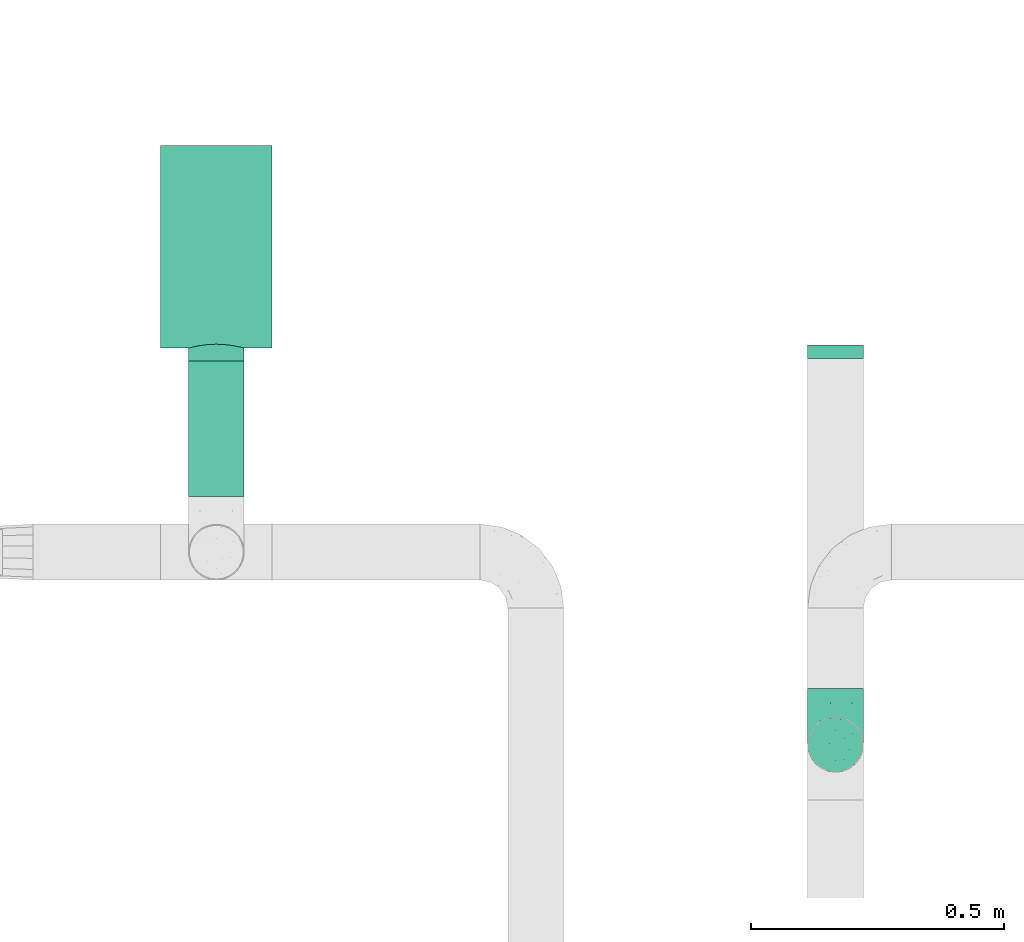
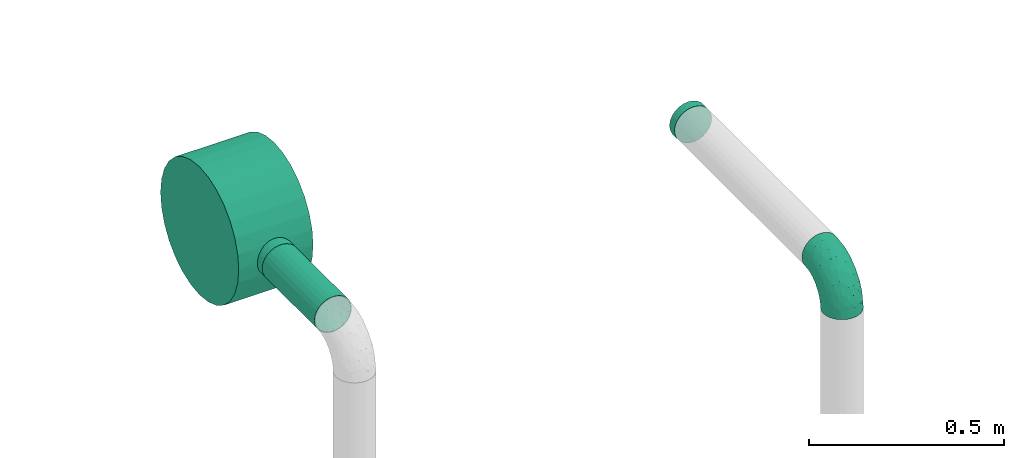
# One storey, part 82 of 103: 3 flow fittings, 1 flow segment.
"""IFC2X3 building model written with IfcOpenShell, lengths in millimetres."""

from ifc_helpers import new_model, entity, si_unit, converted_unit, derived_unit, direction, frame, origin_with_axes, origin_2d_with_axis, place, context, subcontext, project, spatial, hollow_circle, extrude, open_shell, surface_model, source, transform, mapped, material, layer, layer_set, layer_usage, type_object, element, save


model = new_model("IFC2X3")

# Units and contexts
model_context = context("Model", 3, precision=1e-05, world=origin_with_axes(), true_north=direction((0.0, 1.0)))
body_context = subcontext(model_context, "Body", "Model", "MODEL_VIEW")
ifc_project = project(units=[si_unit("AREAUNIT", "SQUARE_METRE"), si_unit("VOLUMEUNIT", "CUBIC_METRE", prefix="DECI"), si_unit("TIMEUNIT", "SECOND"), si_unit("THERMODYNAMICTEMPERATUREUNIT", "DEGREE_CELSIUS"), si_unit("PRESSUREUNIT", "PASCAL"), si_unit("MASSUNIT", "GRAM", prefix="KILO"), si_unit("LENGTHUNIT", "METRE", prefix="MILLI"), si_unit("POWERUNIT", "WATT"), si_unit("ELECTRICCURRENTUNIT", "AMPERE"), si_unit("ELECTRICVOLTAGEUNIT", "VOLT"), derived_unit("VOLUMETRICFLOWRATEUNIT", [(si_unit("VOLUMEUNIT", "CUBIC_METRE", prefix="DECI"), 1), (si_unit("TIMEUNIT", "SECOND"), -1)]), derived_unit("LINEARVELOCITYUNIT", [(si_unit("LENGTHUNIT", "METRE"), 1), (si_unit("TIMEUNIT", "SECOND"), -1)]), derived_unit("MASSDENSITYUNIT", [(si_unit("MASSUNIT", "GRAM", prefix="KILO"), 1), (si_unit("VOLUMEUNIT", "CUBIC_METRE"), -1)]), converted_unit("PLANEANGLEUNIT", "DEGREE", entity("IfcRatioMeasure", 0.01745), si_unit("PLANEANGLEUNIT", "RADIAN"), dimensions=[0, 0, 0, 0, 0, 0, 0])], contexts=[model_context])

# Site, building, storey
site_placement = place(None, origin_with_axes())
site = spatial("IfcSite", under=ifc_project, at=site_placement, CompositionType="ELEMENT")
building_placement = place(site_placement, origin_with_axes())
building = spatial("IfcBuilding", under=site, at=building_placement, Name="mc-building", CompositionType="ELEMENT")
storey_placement = place(building_placement, frame((0.0, 0.0, 5900.0), z_axis=(0.0, 0.0, 1.0), x_axis=(1.0, 0.0, 0.0)))
storey = spatial("IfcBuildingStorey", under=building, at=storey_placement, Name="3. Korrus", CompositionType="ELEMENT", Elevation=5900.0)

# Flow fittings
duct_fitting_type_1 = type_object("IfcDuctFittingType", Name="BU", PredefinedType="BEND")
shared_shape_1 = source(origin_with_axes(), body_context, "Body", "SurfaceModel", [
    surface_model("IfcShellBasedSurfaceModel", [(-110.0, 0.0, -55.0), (-110.0, -14.23505, -53.12592), (-110.0, 14.23505, -53.12592), (-110.0, 53.12592, 14.23505), (-110.0, 27.5, -47.63139), (-110.0, 38.89087, -38.89087), (-110.0, -55.0, 0.0), (-110.0, -53.12592, 14.23505), (-110.0, -38.89087, -38.89087), (-110.0, -27.5, -47.63139), (-110.0, -53.12592, -14.23505), (-110.0, -47.63139, -27.5), (-110.0, -14.23505, 53.12592), (-110.0, 14.23505, 53.12592), (-110.0, 27.5, 47.63139), (-110.0, -47.63139, 27.5), (-110.0, -38.89087, 38.89087), (-110.0, -27.5, 47.63139), (-110.0, 0.0, 55.0), (-110.0, 55.0, 0.0), (-110.0, 53.12592, -14.23505), (-110.0, 47.63139, -27.5), (-110.0, 47.63139, 27.5), (-110.0, 38.89087, 38.89087), (-14.23505, 110.0, -53.12592), (-55.0, 110.0, 0.0), (0.0, 110.0, -55.0), (-27.5, 110.0, -47.63139), (-38.89087, 110.0, -38.89087), (-47.63139, 110.0, -27.5), (38.89087, 110.0, -38.89087), (53.12592, 110.0, 14.23505), (27.5, 110.0, -47.63139), (14.23505, 110.0, -53.12592), (47.63139, 110.0, -27.5), (53.12592, 110.0, -14.23505), (55.0, 110.0, 0.0), (-53.12592, 110.0, -14.23505), (-53.12592, 110.0, 14.23505), (-47.63139, 110.0, 27.5), (-38.89087, 110.0, 38.89087), (-27.5, 110.0, 47.63139), (0.0, 110.0, 55.0), (-14.23505, 110.0, 53.12592), (38.89087, 110.0, 38.89087), (47.63139, 110.0, 27.5), (27.5, 110.0, 47.63139), (14.23505, 110.0, 53.12592), (-64.21732, 48.68956, 43.63444), (-76.6405, 38.18013, 45.55988), (-60.44912, 32.56953, 51.94617), (-76.00813, 5.38378, 55.0), (-90.15553, 11.94394, 54.09138), (-78.5998, 26.77405, 50.81338), (-70.18771, 18.55163, 54.03432), (-75.55424, 54.2118, 32.41257), (-93.27622, 45.77614, 33.48188), (-96.12334, 22.13664, 50.81337), (-21.00813, 45.34362, 55.0), (-18.36258, 70.48427, 54.04484), (-32.04182, 59.64019, 52.24446), (-63.88653, 74.77858, 17.99134), (-74.66383, 63.08407, 19.92123), (-63.60674, 66.07878, 29.97482), (-99.597, 52.72185, 18.52927), (-93.11138, 56.59448, 10.50359), (-98.21577, 57.34403, 0.0), (-53.42855, 92.60092, 21.04759), (-88.54852, 54.8376, 21.04759), (-11.86161, 90.23965, 54.10313), (-5.38378, 76.00813, 55.0), (-57.34403, 98.21577, 0.0), (-56.64619, 93.12774, 10.22088), (-45.34362, 21.00813, 55.0), (-44.60838, 44.60838, 52.13415), (-92.68484, 35.46673, 43.63443), (-22.25266, 95.40765, 50.81337), (-35.97783, 90.61597, 43.63443), (-43.70931, 69.58671, 44.47149), (-27.23711, 77.39884, 50.81337), (-57.2828, 79.3123, 24.9774), (-58.67786, 84.31125, 16.04456), (-82.93277, 60.36161, 12.91784), (-49.88337, 54.51816, 47.224), (-74.57753, 66.83759, 9.55742), (-45.35812, 94.97281, 33.48188), (-59.18663, 88.95241, 0.0), (-51.517, 78.6292, 33.48188), (-65.14788, 80.03077, 0.0), (-56.45322, 62.06476, 39.63545), (-88.95241, 59.18663, 0.0), (-71.10913, 71.10913, 0.0), (-80.03077, 65.14788, 0.0), (-94.9309, 45.36788, -33.48188), (-93.11358, 56.60141, -10.46614), (-99.64997, 52.79499, -18.30015), (-90.20425, 36.08686, -43.63443), (-79.99933, 46.56772, -37.92748), (-76.00813, 5.38378, -55.0), (-72.75364, 19.68651, -53.60527), (-45.34362, 21.00813, -55.0), (-21.91957, 65.12078, -53.85897), (-5.38378, 76.00813, -55.0), (-21.00813, 45.34362, -55.0), (-35.41876, 92.89265, -43.63443), (-91.10309, 11.02766, -54.21832), (-45.77614, 93.27622, -33.48188), (-90.50474, 23.21022, -50.81337), (-70.92854, 33.31794, -49.51754), (-78.52933, 63.35627, -11.73997), (-24.91508, 84.05606, -50.81337), (-88.78941, 54.74452, -21.04759), (-69.59921, 57.34866, -33.48187), (-73.36422, 62.46673, -22.94182), (-63.49062, 67.59111, -28.46929), (-56.59448, 93.11138, -10.50359), (-54.8376, 88.54852, -21.04759), (-54.10679, 75.85581, -32.31867), (-57.75956, 31.09612, -52.80882), (-52.72185, 99.597, -18.52927), (-12.62913, 89.46304, -53.99097), (-34.46825, 66.46123, -50.04329), (-43.9837, 43.9837, -52.42279), (-65.78527, 72.58348, -17.68796), (-70.34468, 43.65295, -44.21951), (-57.47001, 51.99467, -44.91465), (-60.72547, 82.29174, -12.88567), (-42.34915, 74.24548, -43.63444), (-57.25194, 63.5016, -38.08211), (-80.95344, 53.56991, -29.32027), (-52.32891, 4.55257, -54.0482), (32.52942, 47.13398, -30.48571), (14.88266, 20.92917, -33.7947), (14.95561, 36.05775, -42.26543), (30.24048, 70.09027, -41.7461), (19.3559, 65.35825, -48.00507), (-70.35075, -46.44478, -19.5952), (-47.13398, -32.52942, -30.48571), (-28.49299, -30.5778, -16.4009), (-4.55257, 52.32891, -54.0482), (-22.4954, 22.4954, -53.25347), (-75.47368, -11.22546, -52.60718), (-81.32209, -51.5606, -9.98467), (-80.81763, -41.84862, -32.14655), (-70.09027, -30.24048, -41.7461), (-36.05774, -14.95561, -42.26543), (-9.15831, -10.852, -27.8997), (-65.35825, -19.3559, -48.00507), (11.22546, 75.47368, -52.60718), (3.94376, 43.9333, -50.53315), (-13.39742, 13.39743, -48.13058), (-43.9333, -3.94376, -50.53315), (49.37776, 67.29486, 0.0), (41.8609, 47.82256, -9.92641), (50.20582, 74.51695, -9.9731), (18.93131, 11.7156, -17.56239), (-27.5, -32.89419, 0.0), (-1.23348, -12.25375, -12.18106), (41.84862, 80.81763, -32.14655), (35.70604, 41.31408, -20.38235), (46.44478, 70.35075, -19.5952), (32.89419, 27.5, 0.0), (6.67262, -6.67262, 0.0), (-67.29486, -49.37776, 0.0), (-50.36265, -42.95545, -9.51562), (-5.47251, 5.47251, -39.92906), (-70.35075, -46.44478, 19.5952), (-74.51695, -50.20582, 9.9731), (-41.31407, -35.70604, 20.38235), (-47.13398, -32.52942, 30.48571), (-80.81763, -41.84862, 32.14655), (-4.55257, 52.32891, 54.0482), (11.22546, 75.47368, 52.60718), (-43.9333, -3.94376, 50.53315), (-65.35825, -19.3559, 48.00507), (-36.05774, -14.95561, 42.26543), (-70.09027, -30.24048, 41.7461), (-11.7156, -18.93131, 17.56239), (30.5778, 28.49299, 16.4009), (12.25375, 1.23348, 12.18106), (51.5606, 81.32209, 9.98467), (42.95545, 50.36265, 9.51562), (-75.47368, -11.22546, 52.60718), (-52.32891, 4.55257, 54.0482), (3.94376, 43.9333, 50.53315), (-22.4954, 22.4954, 53.25347), (-13.39742, 13.39743, 48.13058), (10.852, 9.15831, 27.8997), (-20.92916, -14.88266, 33.79469), (-47.82256, -41.8609, 9.92641), (32.52942, 47.13398, 30.48571), (46.44478, 70.35075, 19.5952), (41.84862, 80.81763, 32.14655), (30.24048, 70.09027, 41.7461), (19.3559, 65.35825, 48.00507), (14.95561, 36.05775, 42.26543), (-5.47251, 5.47251, 39.92906)], [open_shell([[[0, 1, 2]], [[2, 3, 4]], [[4, 3, 5]], [[2, 6, 7]], [[8, 6, 9]], [[1, 9, 6]], [[10, 6, 11]], [[8, 11, 6]], [[6, 2, 1]], [[12, 13, 14]], [[15, 2, 7]], [[16, 17, 2]], [[2, 17, 12]], [[12, 18, 13]], [[19, 20, 3]], [[5, 3, 21]], [[20, 21, 3]], [[22, 3, 2]], [[23, 22, 2]], [[12, 14, 2]], [[2, 14, 23]], [[15, 16, 2]], [[24, 25, 26]], [[27, 25, 24]], [[25, 28, 29]], [[28, 25, 27]], [[30, 26, 31]], [[26, 30, 32]], [[32, 33, 26]], [[34, 31, 35]], [[31, 34, 30]], [[35, 31, 36]], [[29, 37, 25]], [[38, 39, 26]], [[39, 40, 26]], [[41, 42, 40]], [[42, 26, 40]], [[42, 41, 43]], [[26, 44, 45]], [[31, 26, 45]], [[26, 46, 44]], [[47, 46, 26]], [[42, 47, 26]], [[25, 38, 26]], [[48, 49, 50]], [[18, 51, 52]], [[53, 54, 50]], [[55, 56, 49]], [[56, 22, 23]], [[13, 57, 14]], [[58, 59, 60]], [[61, 62, 63]], [[3, 64, 65]], [[53, 52, 54]], [[3, 65, 66]], [[67, 39, 38]], [[56, 68, 64]], [[65, 64, 68]], [[69, 59, 70]], [[38, 71, 72]], [[73, 58, 74]], [[75, 49, 56]], [[76, 69, 43]], [[53, 57, 52]], [[77, 78, 79]], [[41, 76, 43]], [[43, 69, 42]], [[55, 68, 56]], [[23, 14, 75]], [[76, 77, 79]], [[80, 67, 81]], [[62, 82, 68]], [[60, 78, 83]], [[62, 84, 82]], [[85, 77, 40]], [[81, 67, 72]], [[86, 72, 71]], [[87, 85, 67]], [[61, 81, 88]], [[77, 41, 40]], [[78, 77, 87]], [[23, 75, 56]], [[83, 89, 48]], [[85, 40, 39]], [[62, 68, 55]], [[89, 87, 63]], [[83, 48, 50]], [[57, 75, 14]], [[49, 75, 53]], [[67, 85, 39]], [[87, 77, 85]], [[63, 62, 55]], [[89, 55, 48]], [[80, 63, 87]], [[66, 65, 90]], [[66, 19, 3]], [[84, 91, 92]], [[92, 90, 82]], [[65, 82, 90]], [[61, 84, 62]], [[92, 82, 84]], [[68, 82, 65]], [[3, 22, 64]], [[56, 64, 22]], [[38, 25, 71]], [[81, 72, 86]], [[38, 72, 67]], [[91, 61, 88]], [[80, 81, 61]], [[63, 80, 61]], [[67, 80, 87]], [[77, 76, 41]], [[79, 59, 69]], [[79, 69, 76]], [[42, 69, 70]], [[60, 59, 79]], [[58, 70, 59]], [[78, 60, 79]], [[58, 60, 74]], [[52, 57, 13]], [[75, 57, 53]], [[18, 52, 13]], [[52, 51, 54]], [[51, 73, 54]], [[50, 73, 74]], [[73, 50, 54]], [[50, 74, 83]], [[60, 83, 74]], [[89, 83, 78]], [[87, 89, 78]], [[55, 89, 63]], [[50, 49, 53]], [[55, 49, 48]], [[81, 86, 88]], [[91, 84, 61]], [[5, 21, 93]], [[90, 94, 66]], [[20, 94, 95]], [[96, 93, 97]], [[98, 99, 100]], [[96, 4, 5]], [[101, 102, 103]], [[28, 27, 104]], [[2, 105, 0]], [[104, 106, 28]], [[99, 105, 107]], [[108, 107, 96]], [[90, 109, 94]], [[107, 2, 4]], [[20, 66, 94]], [[27, 24, 110]], [[109, 111, 94]], [[112, 113, 114]], [[37, 115, 71]], [[116, 106, 117]], [[99, 118, 100]], [[116, 115, 119]], [[37, 119, 115]], [[24, 120, 110]], [[121, 110, 101]], [[119, 106, 116]], [[101, 110, 120]], [[122, 103, 100]], [[117, 123, 116]], [[124, 125, 108]], [[115, 116, 126]], [[106, 29, 28]], [[26, 102, 120]], [[127, 104, 110]], [[97, 124, 96]], [[125, 122, 118]], [[128, 127, 125]], [[96, 5, 93]], [[115, 126, 86]], [[117, 106, 127]], [[111, 113, 129]], [[95, 93, 21]], [[97, 129, 112]], [[110, 104, 27]], [[106, 104, 127]], [[96, 107, 4]], [[99, 107, 108]], [[99, 108, 118]], [[105, 99, 98]], [[112, 114, 128]], [[121, 125, 127]], [[20, 19, 66]], [[109, 90, 92]], [[94, 111, 95]], [[91, 123, 109]], [[129, 113, 112]], [[93, 95, 111]], [[21, 20, 95]], [[71, 115, 86]], [[71, 25, 37]], [[123, 91, 88]], [[126, 116, 123]], [[123, 88, 126]], [[86, 126, 88]], [[37, 29, 119]], [[106, 119, 29]], [[129, 93, 111]], [[124, 112, 125]], [[0, 105, 98]], [[107, 105, 2]], [[125, 118, 108]], [[100, 118, 122]], [[93, 129, 97]], [[113, 111, 109]], [[109, 123, 113]], [[114, 123, 117]], [[123, 114, 113]], [[128, 114, 117]], [[127, 128, 117]], [[112, 128, 125]], [[103, 122, 101]], [[110, 121, 127]], [[101, 122, 121]], [[125, 121, 122]], [[26, 120, 24]], [[101, 120, 102]], [[96, 124, 108]], [[92, 91, 109]], [[112, 124, 97]], [[100, 130, 98]], [[131, 132, 133]], [[32, 134, 135]], [[136, 137, 138]], [[139, 140, 103]], [[98, 141, 0]], [[142, 10, 136]], [[143, 144, 137]], [[6, 10, 142]], [[137, 145, 146]], [[144, 147, 145]], [[143, 136, 11]], [[11, 136, 10]], [[8, 143, 11]], [[148, 149, 139]], [[8, 9, 144]], [[9, 1, 147]], [[130, 141, 98]], [[103, 140, 100]], [[148, 135, 149]], [[150, 151, 140]], [[152, 153, 154]], [[130, 140, 151]], [[148, 26, 33]], [[147, 1, 141]], [[155, 146, 132]], [[156, 138, 157]], [[134, 30, 158]], [[150, 140, 149]], [[158, 30, 34]], [[30, 134, 32]], [[153, 159, 160]], [[131, 160, 159]], [[144, 145, 137]], [[36, 152, 154]], [[146, 138, 137]], [[155, 161, 162]], [[158, 160, 131]], [[133, 149, 135]], [[156, 163, 164]], [[163, 142, 164]], [[139, 103, 102]], [[153, 152, 161]], [[34, 35, 160]], [[162, 157, 155]], [[132, 165, 133]], [[157, 146, 155]], [[140, 130, 100]], [[141, 130, 151]], [[141, 151, 147]], [[141, 1, 0]], [[102, 26, 148]], [[140, 139, 149]], [[102, 148, 139]], [[135, 33, 32]], [[151, 150, 145]], [[9, 147, 144]], [[151, 145, 147]], [[145, 165, 146]], [[135, 148, 33]], [[133, 135, 134]], [[131, 133, 134]], [[133, 165, 150]], [[133, 150, 149]], [[145, 150, 165]], [[132, 131, 159]], [[146, 165, 132]], [[160, 158, 34]], [[134, 158, 131]], [[144, 143, 8]], [[136, 143, 137]], [[155, 153, 161]], [[154, 153, 160]], [[153, 155, 159]], [[132, 159, 155]], [[160, 35, 154]], [[36, 154, 35]], [[164, 136, 138]], [[6, 142, 163]], [[136, 164, 142]], [[156, 164, 138]], [[156, 157, 162]], [[146, 157, 138]], [[15, 7, 166]], [[6, 163, 167]], [[168, 169, 166]], [[166, 169, 170]], [[171, 172, 70]], [[173, 174, 175]], [[17, 176, 174]], [[177, 156, 162]], [[176, 16, 170]], [[170, 16, 15]], [[161, 178, 179]], [[152, 180, 181]], [[182, 173, 183]], [[18, 12, 182]], [[184, 185, 186]], [[183, 185, 73]], [[183, 73, 51]], [[177, 187, 188]], [[189, 168, 166]], [[187, 178, 190]], [[16, 176, 17]], [[161, 152, 181]], [[45, 191, 31]], [[45, 44, 192]], [[192, 191, 45]], [[180, 36, 31]], [[193, 194, 195]], [[46, 47, 194]], [[193, 195, 190]], [[193, 44, 46]], [[172, 42, 70]], [[185, 58, 73]], [[189, 163, 156]], [[163, 189, 167]], [[70, 58, 171]], [[184, 171, 185]], [[169, 188, 175]], [[180, 31, 191]], [[192, 193, 190]], [[191, 190, 178]], [[182, 174, 173]], [[194, 47, 172]], [[190, 195, 187]], [[186, 185, 173]], [[162, 179, 177]], [[188, 196, 175]], [[179, 187, 177]], [[185, 171, 58]], [[172, 171, 184]], [[172, 184, 194]], [[172, 47, 42]], [[51, 18, 182]], [[185, 183, 173]], [[51, 182, 183]], [[174, 12, 17]], [[184, 186, 195]], [[46, 194, 193]], [[184, 195, 194]], [[195, 196, 187]], [[174, 182, 12]], [[175, 174, 176]], [[169, 175, 176]], [[175, 196, 186]], [[175, 186, 173]], [[195, 186, 196]], [[188, 169, 168]], [[187, 196, 188]], [[166, 170, 15]], [[176, 170, 169]], [[193, 192, 44]], [[191, 192, 190]], [[177, 189, 156]], [[167, 189, 166]], [[189, 177, 168]], [[188, 168, 177]], [[166, 7, 167]], [[6, 167, 7]], [[181, 191, 178]], [[36, 180, 152]], [[191, 181, 180]], [[161, 181, 178]], [[161, 179, 162]], [[187, 179, 178]]])]),
])
flow_fitting_1_placement = place(storey_placement, frame((26894.1474, 9098.55564, 4144.0), z_axis=(-1.0, 0.0, 0.0), x_axis=(0.0, 0.0, 1.0)))
element("IfcFlowFitting", 1, at=flow_fitting_1_placement, inside=storey, type_object=duct_fitting_type_1, Name="BU", context=body_context, shape_type="MappedRepresentation", body=[
    mapped(shared_shape_1, transform((0.0, 0.0, 0.0), scale=1.0)),
])
duct_fitting_type_2 = type_object("IfcDuctFittingType", Name="CC", PredefinedType="CONNECTOR")
shared_shape_2 = source(origin_with_axes(), body_context, "Body", "SurfaceModel", [
    surface_model("IfcShellBasedSurfaceModel", [(-6.096, -55.0, 0.0), (-6.096, 0.0, -55.0), (-6.096, -14.23505, -53.12592), (-6.096, -27.5, -47.63139), (-6.096, -38.89087, -38.89087), (-6.096, -47.63139, -27.5), (-6.096, 38.89087, -38.89087), (-6.096, 53.12592, 14.23505), (-6.096, 27.5, -47.63139), (-6.096, 14.23505, -53.12592), (-6.096, 47.63139, -27.5), (-6.096, 53.12592, -14.23505), (-6.096, 55.0, 0.0), (-6.096, -53.12592, -14.23505), (-6.096, -53.12592, 14.23505), (-6.096, -47.63139, 27.5), (-6.096, -38.89087, 38.89087), (-6.096, 0.0, 55.0), (-6.096, -27.5, 47.63139), (-6.096, -14.23505, 53.12592), (-6.096, 38.89087, 38.89087), (-6.096, 47.63139, 27.5), (-6.096, 14.23505, 53.12592), (-6.096, 27.5, 47.63139), (0.0, -14.23505, 53.12592), (0.0, 0.0, 55.0), (0.0, -27.5, 47.63139), (0.0, -38.89087, 38.89087), (0.0, -53.12592, 14.23505), (0.0, -47.63139, 27.5), (0.0, -55.0, 0.0), (0.0, -53.12592, -14.23505), (0.0, -47.63139, -27.5), (0.0, -38.89087, -38.89087), (0.0, -14.23505, -53.12592), (0.0, -27.5, -47.63139), (0.0, 0.0, -55.0), (0.0, 14.23505, -53.12592), (0.0, 27.5, -47.63139), (0.0, 38.89087, -38.89087), (0.0, 53.12592, -14.23505), (0.0, 47.63139, -27.5), (0.0, 55.0, 0.0), (0.0, 53.12592, 14.23505), (0.0, 47.63139, 27.5), (0.0, 38.89087, 38.89087), (0.0, 14.23505, 53.12592), (0.0, 27.5, 47.63139), (20.0, 0.0, -55.0), (20.0, 14.23505, -53.12592), (20.0, -14.23505, -53.12592), (20.0, -53.12592, 14.23505), (20.0, -27.5, -47.63139), (20.0, -47.63139, -27.5), (20.0, -38.89087, -38.89087), (20.0, 55.0, 0.0), (20.0, 53.12592, 14.23505), (20.0, 38.89087, -38.89087), (20.0, 27.5, -47.63139), (20.0, 53.12592, -14.23505), (20.0, 47.63139, -27.5), (20.0, -53.12592, -14.23505), (20.0, -47.63139, 27.5), (20.0, -38.89087, 38.89087), (20.0, 14.23505, 53.12592), (20.0, -27.5, 47.63139), (20.0, -14.23505, 53.12592), (20.0, 47.63139, 27.5), (20.0, 38.89087, 38.89087), (20.0, 27.5, 47.63139), (20.0, 0.0, 55.0), (20.0, -55.0, 0.0)], [open_shell([[[0, 1, 2]], [[3, 0, 2]], [[0, 4, 5]], [[4, 0, 3]], [[6, 1, 7]], [[1, 6, 8]], [[8, 9, 1]], [[6, 7, 10]], [[10, 7, 11]], [[12, 11, 7]], [[13, 0, 5]], [[14, 15, 1]], [[1, 15, 16]], [[17, 16, 18]], [[17, 1, 16]], [[19, 17, 18]], [[20, 21, 1]], [[7, 1, 21]], [[22, 23, 1]], [[23, 20, 1]], [[22, 1, 17]], [[0, 14, 1]], [[24, 25, 17]], [[26, 24, 19]], [[19, 24, 17]], [[16, 27, 18]], [[26, 19, 18]], [[26, 18, 27]], [[28, 29, 15]], [[30, 28, 14]], [[15, 29, 16]], [[28, 15, 14]], [[30, 14, 0]], [[27, 16, 29]], [[31, 30, 0]], [[32, 31, 13]], [[13, 31, 0]], [[4, 33, 5]], [[32, 13, 5]], [[32, 5, 33]], [[34, 35, 3]], [[36, 34, 2]], [[3, 35, 4]], [[34, 3, 2]], [[36, 2, 1]], [[33, 4, 35]], [[37, 36, 1]], [[38, 37, 9]], [[9, 37, 1]], [[6, 39, 8]], [[38, 9, 8]], [[38, 8, 39]], [[40, 41, 10]], [[42, 40, 11]], [[10, 41, 6]], [[40, 10, 11]], [[42, 11, 12]], [[39, 6, 41]], [[43, 42, 12]], [[44, 43, 7]], [[7, 43, 12]], [[20, 45, 21]], [[44, 7, 21]], [[44, 21, 45]], [[46, 47, 23]], [[25, 46, 22]], [[23, 47, 20]], [[46, 23, 22]], [[25, 22, 17]], [[45, 20, 47]], [[48, 49, 50]], [[50, 51, 52]], [[53, 54, 51]], [[52, 51, 54]], [[50, 55, 56]], [[57, 55, 58]], [[49, 58, 55]], [[59, 55, 60]], [[57, 60, 55]], [[55, 50, 49]], [[53, 51, 61]], [[50, 62, 51]], [[63, 62, 50]], [[64, 65, 50]], [[65, 63, 50]], [[64, 66, 65]], [[50, 67, 68]], [[67, 50, 56]], [[68, 69, 50]], [[50, 69, 64]], [[64, 70, 66]], [[71, 61, 51]], [[66, 70, 25]], [[65, 66, 24]], [[24, 66, 25]], [[27, 63, 26]], [[65, 24, 26]], [[65, 26, 63]], [[51, 62, 29]], [[71, 51, 28]], [[29, 62, 27]], [[51, 29, 28]], [[71, 28, 30]], [[63, 27, 62]], [[61, 71, 30]], [[53, 61, 31]], [[31, 61, 30]], [[33, 54, 32]], [[53, 31, 32]], [[53, 32, 54]], [[50, 52, 35]], [[48, 50, 34]], [[35, 52, 33]], [[50, 35, 34]], [[48, 34, 36]], [[54, 33, 52]], [[49, 48, 36]], [[58, 49, 37]], [[37, 49, 36]], [[39, 57, 38]], [[58, 37, 38]], [[58, 38, 57]], [[59, 60, 41]], [[55, 59, 40]], [[41, 60, 39]], [[59, 41, 40]], [[55, 40, 42]], [[57, 39, 60]], [[56, 55, 42]], [[67, 56, 43]], [[43, 56, 42]], [[45, 68, 44]], [[67, 43, 44]], [[67, 44, 68]], [[64, 69, 47]], [[70, 64, 46]], [[47, 69, 45]], [[64, 47, 46]], [[70, 46, 25]], [[68, 45, 69]], [[50, 63, 62]], [[50, 64, 65]], [[50, 56, 67]], [[50, 68, 69]], [[64, 50, 69]]])]),
])
flow_fitting_2_placement = place(storey_placement, frame((26894.1474, 9880.05037, 4144.0), z_axis=(0.0, 0.0, -1.0), x_axis=(0.0, -1.0, 0.0)))
element("IfcFlowFitting", 2, at=flow_fitting_2_placement, inside=storey, type_object=duct_fitting_type_2, Name="CC", context=body_context, shape_type="MappedRepresentation", body=[
    mapped(shared_shape_2, transform((0.0, 0.0, 0.0), scale=1.0)),
])

# Flow segment
ifc_material = material(Name="FZ1")
ifc_layer = layer(ifc_material, 0.0)
ifc_layer_set = layer_set([ifc_layer], Name="FZ1")
ifc_layer_usage = layer_usage(ifc_layer_set, "AXIS1", "POSITIVE", 0.0)
duct_segment_type = type_object("IfcDuctSegmentType", Name="Safe", PredefinedType="RIGIDSEGMENT")
shared_shape_3 = source(origin_with_axes(), body_context, "Body", "SweptSolid", [
    extrude(hollow_circle(Radius=55.0, WallThickness=2.0, at=origin_2d_with_axis()), frame((0.0, 0.0, 0.0), z_axis=(1.0, 0.0, 0.0), x_axis=(0.0, 1.0, 0.0)), (0.0, 0.0, 1.0), 267.4),
])
flow_segment_placement = place(storey_placement, frame((25672.59509, 9855.05037, 4144.0), z_axis=(0.0, 0.0, 1.0), x_axis=(0.0, -1.0, 0.0)))
element("IfcFlowSegment", 3, at=flow_segment_placement, inside=storey, type_object=duct_segment_type, material=ifc_layer_usage, Name="Safe", context=body_context, shape_type="MappedRepresentation", body=[
    mapped(shared_shape_3, transform((0.0, 0.0, 0.0), scale=1.0)),
])

# Flow fitting
duct_fitting_type_3 = type_object("IfcDuctFittingType", PredefinedType="JUNCTION")
shared_shape_4 = source(origin_with_axes(), body_context, "Body", "SurfaceModel", [
    surface_model("IfcShellBasedSurfaceModel", [(0.0, -225.0, -55.0), (14.23505, -225.0, -53.12592), (-14.23505, -225.0, -53.12592), (-53.12592, -225.0, 14.23505), (-27.5, -225.0, -47.63139), (-47.63139, -225.0, -27.5), (-38.89087, -225.0, -38.89087), (55.0, -225.0, 0.0), (53.12592, -225.0, 14.23505), (38.89087, -225.0, -38.89087), (27.5, -225.0, -47.63139), (53.12592, -225.0, -14.23505), (47.63139, -225.0, -27.5), (-53.12592, -225.0, -14.23505), (-47.63139, -225.0, 27.5), (-38.89087, -225.0, 38.89087), (14.23505, -225.0, 53.12592), (-27.5, -225.0, 47.63139), (-14.23505, -225.0, 53.12592), (47.63139, -225.0, 27.5), (38.89087, -225.0, 38.89087), (27.5, -225.0, 47.63139), (0.0, -225.0, 55.0), (-55.0, -225.0, 0.0), (0.0, -192.28884, 55.0), (-12.29394, -192.68144, 53.60839), (-23.92751, -193.77184, 49.52246), (-34.31923, -195.32745, 42.97895), (-42.9874, -197.03532, 34.30865), (-49.52973, -198.56533, 23.91246), (-53.61252, -199.6229, 12.27592), (-55.0, -200.0, 0.0), (-49.52091, -198.56313, -23.93071), (-42.97449, -197.0325, -34.32482), (-53.60826, -199.62175, -12.29447), (-34.30293, -195.32458, -42.99196), (-23.90904, -193.76957, -49.53138), (-12.27509, -192.68024, -53.61271), (0.0, -192.28884, -55.0), (12.29394, -192.68144, -53.60839), (23.92751, -193.77184, -49.52246), (34.31923, -195.32745, -42.97895), (42.9874, -197.03532, -34.30865), (49.52973, -198.56533, -23.91246), (53.61252, -199.6229, -12.27592), (55.0, -200.0, 0.0), (49.52973, -198.56533, 23.91246), (42.9874, -197.03532, 34.30865), (53.61252, -199.6229, 12.27592), (34.31923, -195.32745, 42.97895), (23.92751, -193.77184, 49.52246), (12.29394, -192.68144, 53.60839), (-110.0, 0.0, -200.0), (-110.0, -44.50419, -194.98559), (-110.0, 44.50419, -194.98559), (-110.0, 194.98559, 44.50419), (-110.0, 86.77674, -180.19378), (-110.0, 180.19378, -86.77674), (-110.0, 156.36629, -124.69796), (-110.0, 124.69796, -156.36629), (-110.0, -200.0, 0.0), (-110.0, -194.98559, 44.50419), (-110.0, -124.69796, -156.36629), (-110.0, -86.77674, -180.19378), (-110.0, -156.36629, -124.69796), (-110.0, -180.19378, -86.77674), (-110.0, -194.98559, -44.50419), (-110.0, 194.98559, -44.50419), (-110.0, 180.19378, 86.77674), (-110.0, 156.36629, 124.69796), (-110.0, 86.77674, 180.19378), (-110.0, 124.69796, 156.36629), (-110.0, 44.50419, 194.98559), (-110.0, 0.0, 200.0), (-110.0, -156.36629, 124.69796), (-110.0, -180.19378, 86.77674), (-110.0, -86.77674, 180.19378), (-110.0, -44.50419, 194.98559), (-110.0, -124.69796, 156.36629), (-110.0, 200.0, 0.0), (110.0, 0.0, -200.0), (110.0, 44.50419, -194.98559), (110.0, 86.77674, -180.19378), (110.0, 200.0, 0.0), (110.0, 156.36629, -124.69796), (110.0, 180.19378, -86.77674), (110.0, 124.69796, -156.36629), (110.0, -156.36629, -124.69796), (110.0, -194.98559, 44.50419), (110.0, -86.77674, -180.19378), (110.0, -44.50419, -194.98559), (110.0, -124.69796, -156.36629), (110.0, -180.19378, -86.77674), (110.0, -194.98559, -44.50419), (110.0, -200.0, 0.0), (110.0, 194.98559, -44.50419), (110.0, 194.98559, 44.50419), (110.0, 180.19378, 86.77674), (110.0, 156.36629, 124.69796), (110.0, 124.69796, 156.36629), (110.0, 86.77674, 180.19378), (110.0, 44.50419, 194.98559), (110.0, -156.36629, 124.69796), (110.0, -180.19378, 86.77674), (110.0, -124.69796, 156.36629), (110.0, -86.77674, 180.19378), (110.0, -44.50419, 194.98559), (110.0, 0.0, 200.0), (-110.0, -197.4928, -22.25209), (110.0, -197.4928, -22.25209), (110.0, -197.4928, 22.25209), (-110.0, -197.4928, 22.25209)], [open_shell([[[0, 1, 2]], [[2, 3, 4]], [[5, 6, 3]], [[6, 4, 3]], [[2, 7, 8]], [[9, 7, 10]], [[1, 10, 7]], [[11, 7, 12]], [[9, 12, 7]], [[7, 2, 1]], [[5, 3, 13]], [[2, 14, 3]], [[2, 15, 14]], [[2, 16, 17]], [[17, 15, 2]], [[16, 18, 17]], [[2, 8, 19]], [[2, 19, 20]], [[2, 20, 21]], [[16, 2, 21]], [[16, 22, 18]], [[23, 13, 3]], [[22, 24, 25]], [[18, 25, 26]], [[22, 25, 18]], [[17, 27, 15]], [[17, 18, 26]], [[27, 17, 26]], [[28, 29, 14]], [[30, 31, 23]], [[29, 30, 3]], [[15, 28, 14]], [[3, 14, 29]], [[23, 3, 30]], [[28, 15, 27]], [[32, 33, 5]], [[34, 32, 13]], [[31, 34, 23]], [[23, 34, 13]], [[32, 5, 13]], [[33, 6, 5]], [[4, 35, 36]], [[36, 37, 2]], [[38, 0, 37]], [[4, 6, 35]], [[2, 4, 36]], [[37, 0, 2]], [[35, 6, 33]], [[0, 38, 39]], [[1, 39, 40]], [[0, 39, 1]], [[10, 41, 9]], [[10, 1, 40]], [[41, 10, 40]], [[42, 43, 12]], [[44, 45, 7]], [[43, 44, 11]], [[9, 42, 12]], [[11, 12, 43]], [[7, 11, 44]], [[42, 9, 41]], [[46, 47, 19]], [[48, 46, 8]], [[45, 48, 7]], [[7, 48, 8]], [[46, 19, 8]], [[47, 20, 19]], [[21, 49, 50]], [[50, 51, 16]], [[24, 22, 51]], [[20, 49, 21]], [[16, 21, 50]], [[22, 16, 51]], [[49, 20, 47]], [[52, 53, 54]], [[54, 55, 56]], [[55, 57, 58]], [[58, 59, 55]], [[59, 56, 55]], [[54, 60, 61]], [[62, 60, 63]], [[54, 53, 63]], [[60, 64, 65]], [[65, 66, 60]], [[60, 62, 64]], [[63, 60, 54]], [[55, 67, 57]], [[54, 68, 55]], [[54, 69, 68]], [[70, 71, 69]], [[70, 54, 72]], [[70, 69, 54]], [[72, 54, 73]], [[74, 73, 75]], [[54, 61, 75]], [[76, 77, 73]], [[73, 78, 76]], [[74, 78, 73]], [[54, 75, 73]], [[79, 67, 55]], [[80, 81, 82]], [[83, 80, 82]], [[84, 85, 83]], [[83, 86, 84]], [[83, 82, 86]], [[87, 80, 88]], [[80, 89, 90]], [[80, 91, 89]], [[91, 80, 87]], [[87, 88, 92]], [[93, 92, 88]], [[93, 88, 94]], [[85, 95, 83]], [[83, 96, 97]], [[98, 80, 97]], [[98, 99, 100]], [[80, 100, 101]], [[80, 98, 100]], [[80, 101, 102]], [[102, 103, 80]], [[88, 80, 103]], [[104, 102, 101]], [[104, 101, 105]], [[101, 106, 105]], [[101, 107, 106]], [[83, 97, 80]], [[72, 107, 101]], [[70, 101, 100]], [[71, 100, 99]], [[73, 107, 72]], [[72, 101, 70]], [[100, 71, 70]], [[99, 69, 71]], [[68, 98, 97]], [[55, 97, 96]], [[79, 96, 83]], [[69, 98, 68]], [[68, 97, 55]], [[96, 79, 55]], [[98, 69, 99]], [[83, 95, 79]], [[85, 84, 58]], [[95, 85, 67]], [[67, 79, 95]], [[58, 57, 85]], [[67, 85, 57]], [[84, 59, 58]], [[56, 86, 82]], [[54, 82, 81]], [[52, 81, 80]], [[59, 86, 56]], [[56, 82, 54]], [[81, 52, 54]], [[86, 59, 84]], [[90, 53, 80]], [[89, 63, 90]], [[65, 87, 92]], [[89, 91, 62]], [[87, 64, 91]], [[92, 40, 39]], [[39, 38, 92]], [[53, 90, 63]], [[62, 63, 89]], [[53, 52, 80]], [[38, 37, 65]], [[34, 108, 32]], [[64, 87, 65]], [[37, 36, 65]], [[64, 62, 91]], [[38, 65, 92]], [[42, 109, 43]], [[93, 42, 41]], [[93, 109, 42]], [[41, 40, 93]], [[93, 40, 92]], [[94, 45, 44]], [[43, 109, 44]], [[44, 109, 94]], [[36, 35, 66]], [[33, 32, 108]], [[33, 66, 35]], [[36, 66, 65]], [[34, 60, 108]], [[31, 60, 34]], [[108, 66, 33]], [[45, 94, 48]], [[94, 110, 48]], [[110, 47, 46]], [[47, 110, 88]], [[49, 47, 88]], [[29, 111, 30]], [[60, 31, 30]], [[111, 60, 30]], [[27, 26, 61]], [[61, 111, 28]], [[61, 28, 27]], [[26, 75, 61]], [[49, 88, 50]], [[51, 103, 24]], [[48, 110, 46]], [[51, 50, 103]], [[74, 103, 102]], [[103, 50, 88]], [[105, 106, 77]], [[76, 104, 105]], [[78, 102, 104]], [[73, 106, 107]], [[25, 24, 75]], [[28, 111, 29]], [[75, 24, 103]], [[74, 75, 103]], [[25, 75, 26]], [[102, 78, 74]], [[104, 76, 78]], [[77, 76, 105]], [[106, 73, 77]]])]),
])
flow_fitting_3_placement = place(storey_placement, frame((25672.59509, 10080.05037, 4144.0), z_axis=(0.0, 0.0, 1.0), x_axis=(1.0, 0.0, 0.0)))
element("IfcFlowFitting", 4, at=flow_fitting_3_placement, inside=storey, type_object=duct_fitting_type_3, context=body_context, shape_type="MappedRepresentation", body=[
    mapped(shared_shape_4, transform((0.0, 0.0, 0.0), scale=1.0)),
])

save(model, "model.ifc")
